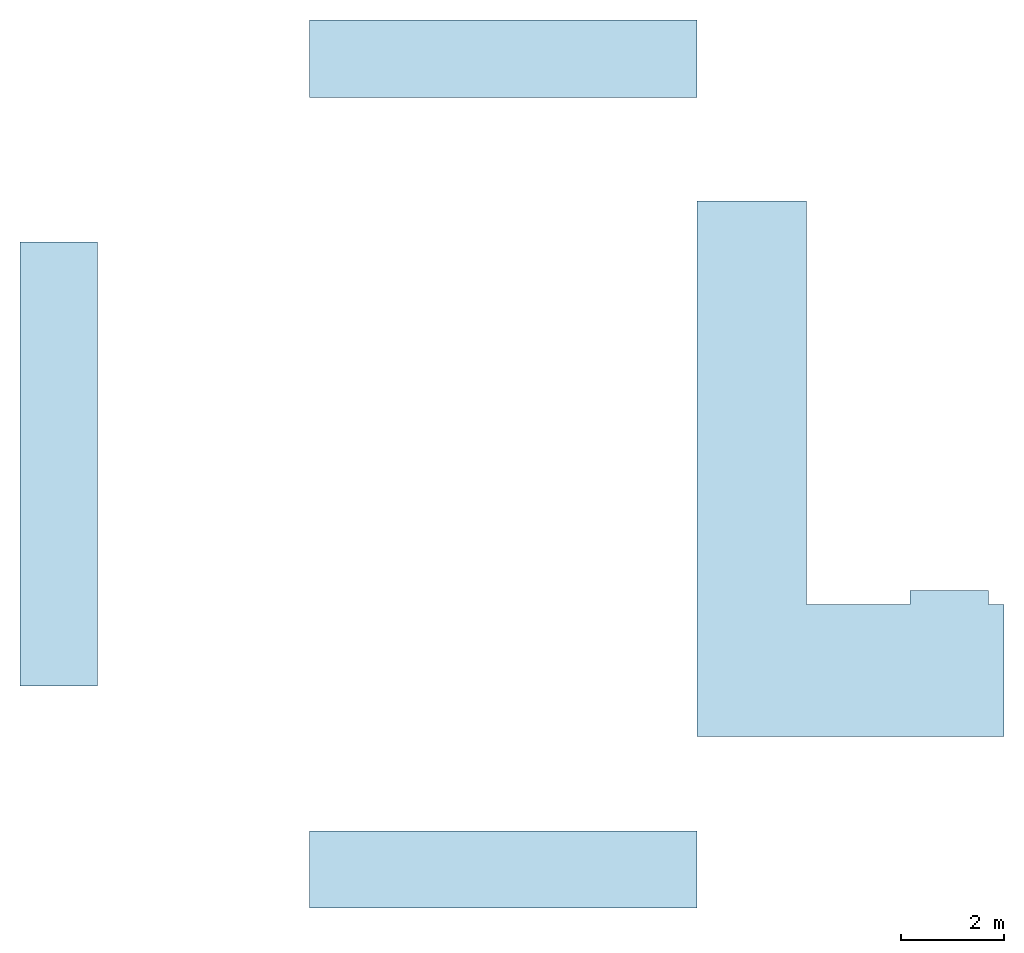
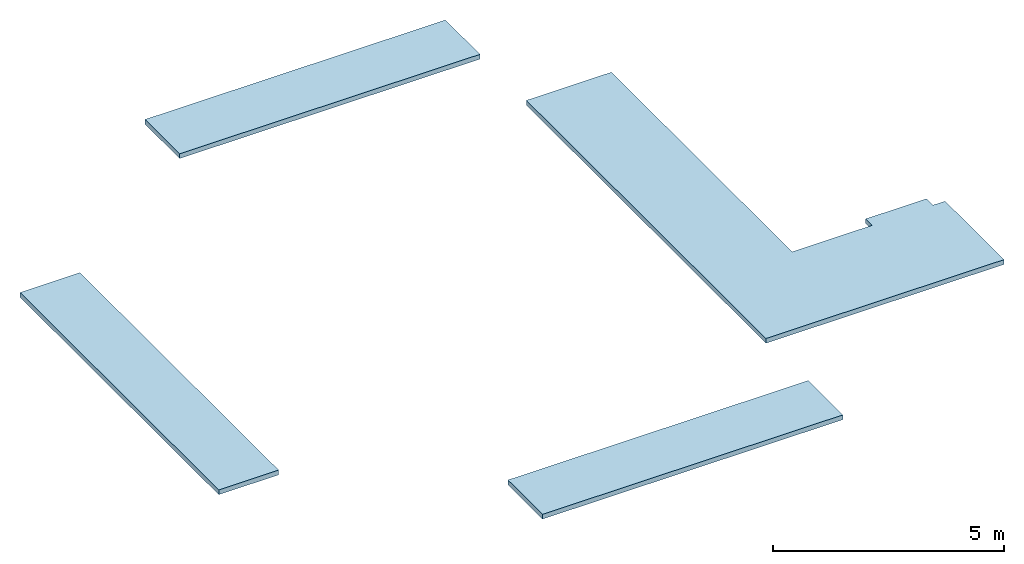
# One storey: 4 slabs.
"""IFC2X3 building model written with IfcOpenShell, lengths in millimetres."""

from ifc_helpers import new_model, entity, si_unit, converted_unit, derived_unit, direction, frame, frame_2d, origin, place, context, subcontext, project, spatial, polyline, rectangle, outline, extrude, material, layer, layer_set, layer_usage, type_object, element, save


model = new_model("IFC2X3")

# Units and contexts
model_context = context("Model", 3, precision=0.01, world=origin(), true_north=direction((6.12303176911189e-17, 1.0)))
body_context = subcontext(model_context, "Body", "Model", "MODEL_VIEW")
ifc_project = project(units=[si_unit("LENGTHUNIT", "METRE", prefix="MILLI"), si_unit("AREAUNIT", "SQUARE_METRE"), si_unit("VOLUMEUNIT", "CUBIC_METRE"), converted_unit("PLANEANGLEUNIT", "DEGREE", entity("IfcRatioMeasure", 0.0174532925199433), si_unit("PLANEANGLEUNIT", "RADIAN"), dimensions=[0, 0, 0, 0, 0, 0, 0]), si_unit("MASSUNIT", "GRAM", prefix="KILO"), derived_unit("MASSDENSITYUNIT", [(si_unit("MASSUNIT", "GRAM", prefix="KILO"), 1), (si_unit("LENGTHUNIT", "METRE"), -3)]), si_unit("TIMEUNIT", "SECOND"), si_unit("FREQUENCYUNIT", "HERTZ"), si_unit("THERMODYNAMICTEMPERATUREUNIT", "DEGREE_CELSIUS"), derived_unit("THERMALTRANSMITTANCEUNIT", [(si_unit("MASSUNIT", "GRAM", prefix="KILO"), 1), (si_unit("THERMODYNAMICTEMPERATUREUNIT", "KELVIN"), -1), (si_unit("TIMEUNIT", "SECOND"), -3)]), derived_unit("VOLUMETRICFLOWRATEUNIT", [(si_unit("LENGTHUNIT", "METRE"), 3), (si_unit("TIMEUNIT", "SECOND"), -1)]), si_unit("ELECTRICCURRENTUNIT", "AMPERE"), si_unit("ELECTRICVOLTAGEUNIT", "VOLT"), si_unit("POWERUNIT", "WATT"), si_unit("FORCEUNIT", "NEWTON", prefix="KILO"), si_unit("ILLUMINANCEUNIT", "LUX"), si_unit("LUMINOUSFLUXUNIT", "LUMEN"), si_unit("LUMINOUSINTENSITYUNIT", "CANDELA"), derived_unit("USERDEFINED", [(si_unit("MASSUNIT", "GRAM", prefix="KILO"), -1), (si_unit("LENGTHUNIT", "METRE"), -2), (si_unit("TIMEUNIT", "SECOND"), 3), (si_unit("LUMINOUSFLUXUNIT", "LUMEN"), 1)]), derived_unit("LINEARVELOCITYUNIT", [(si_unit("LENGTHUNIT", "METRE"), 1), (si_unit("TIMEUNIT", "SECOND"), -1)]), si_unit("PRESSUREUNIT", "PASCAL"), derived_unit("USERDEFINED", [(si_unit("LENGTHUNIT", "METRE"), -2), (si_unit("MASSUNIT", "GRAM", prefix="KILO"), 1), (si_unit("TIMEUNIT", "SECOND"), -2)])], contexts=[model_context])

# Site, building, storey
site_placement = place(None, origin())
site = spatial("IfcSite", under=ifc_project, at=site_placement, CompositionType="ELEMENT")
building_placement = place(site_placement, origin())
building = spatial("IfcBuilding", under=site, at=building_placement, CompositionType="ELEMENT")
storey_placement = place(building_placement, frame((0.0, 0.0, 4000.0)))
storey = spatial("IfcBuildingStorey", under=building, at=storey_placement, Name="01 Level", CompositionType="ELEMENT", Elevation=4000.0)

# Slabs
ifc_material_1 = material()
ifc_layer_1 = layer(ifc_material_1, 110.0)
ifc_material_2 = material(Name="03")
ifc_layer_2 = layer(ifc_material_2, 15.0)
ifc_layer_set = layer_set([ifc_layer_1, ifc_layer_2], Name="Floor")
ifc_layer_usage_1 = layer_usage(ifc_layer_set, "AXIS3", "POSITIVE", 0.0)
slab_type_1 = type_object("IfcSlabType", Name="Floor", PredefinedType="FLOOR")
slab_1_placement = place(storey_placement, frame((15673.4900708517, -77451.2395851399, -465.0)))
element("IfcSlab", 1, at=slab_1_placement, inside=storey, type_object=slab_type_1, material=ifc_layer_usage_1, Name="Floor", ObjectType="Floor", PredefinedType="FLOOR", context=body_context, shape_type="SweptSolid", body=[
    extrude(rectangle(XDim=7520.0, YDim=1499.99999999999, at=frame_2d((-2810.0, -7870.0), x_axis=(-1.0, 0.0))), frame((6570.0, 8620.0, 125.0), z_axis=(0.0, 0.0, -1.0), x_axis=(-1.0, 0.0, 0.0)), (0.0, 0.0, 1.0), 125.0),
])
slab_type_2 = type_object("IfcSlabType", Name="Floor", PredefinedType="FLOOR")
slab_2_placement = place(storey_placement, frame((15673.4900708517, -77451.2395851399, -465.0)))
element("IfcSlab", 2, at=slab_2_placement, inside=storey, type_object=slab_type_2, material=ifc_layer_usage_1, Name="Floor:2", ObjectType="Floor", PredefinedType="FLOOR", context=body_context, shape_type="SweptSolid", body=[
    extrude(rectangle(XDim=8619.99999999999, YDim=1500.00000000002, at=frame_2d((5820.0, 0.0), x_axis=(0.0, 1.0))), frame((6570.0, 8620.0, 125.0), z_axis=(0.0, 0.0, -1.0), x_axis=(-1.0, 0.0, 0.0)), (0.0, 0.0, 1.0), 125.0),
])
slab_type_3 = type_object("IfcSlabType", Name="Floor", PredefinedType="FLOOR", material=ifc_layer_set)
slab_3_placement = place(storey_placement, frame((15673.4900708517, -77451.2395851399, -465.0)))
element("IfcSlab", 3, at=slab_3_placement, inside=storey, type_object=slab_type_3, material=ifc_layer_usage_1, Name="Floor:3", ObjectType="Floor", PredefinedType="FLOOR", context=body_context, shape_type="SweptSolid", body=[
    extrude(rectangle(XDim=1500.0, YDim=7520.0, at=frame_2d((-2810.0, 7870.0), x_axis=(0.0, 1.0))), frame((6570.0, 8620.0, 125.0), z_axis=(0.0, 0.0, -1.0), x_axis=(-1.0, 0.0, 0.0)), (0.0, 0.0, 1.0), 125.0),
])
ifc_layer_usage_2 = layer_usage(ifc_layer_set, "AXIS3", "POSITIVE", 0.0)
slab_type_4 = type_object("IfcSlabType", Name="Floor", PredefinedType="FLOOR", material=ifc_layer_set)
slab_4_placement = place(storey_placement, origin())
element("IfcSlab", 4, at=slab_4_placement, inside=storey, type_object=slab_type_4, material=ifc_layer_usage_2, Name="Floor", ObjectType="Floor", PredefinedType="FLOOR", context=body_context, shape_type="SweptSolid", body=[
    extrude(outline(polyline([(-3668.0, -3576.83630606416), (6727.0, -3576.83630606416), (6727.0, -1446.83630606415), (-1113.0, -1446.83630606415), (-1113.0, 557.345224256676), (-833.0, 557.345224256676), (-833.0, 2083.16369393581), (-1113.0, 2083.16369393581), (-1113.0, 2383.16369393581), (-3668.0, 2383.16369393581), (-3668.0, -3576.83630606416)])), frame((32390.326376916, -70447.8241905964, -340.0), z_axis=(0.0, 0.0, -1.0), x_axis=(0.0, 1.0, 0.0)), (0.0, 0.0, 1.0), 125.0),
])

save(model, "model.ifc")
